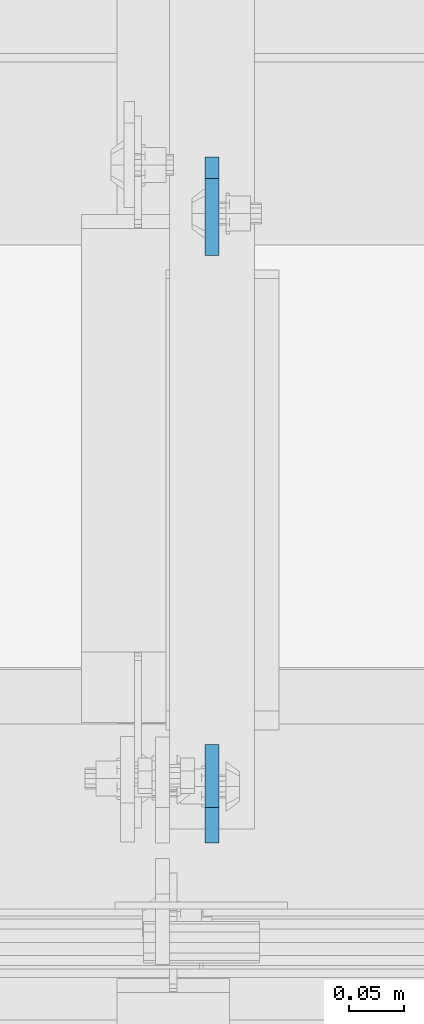
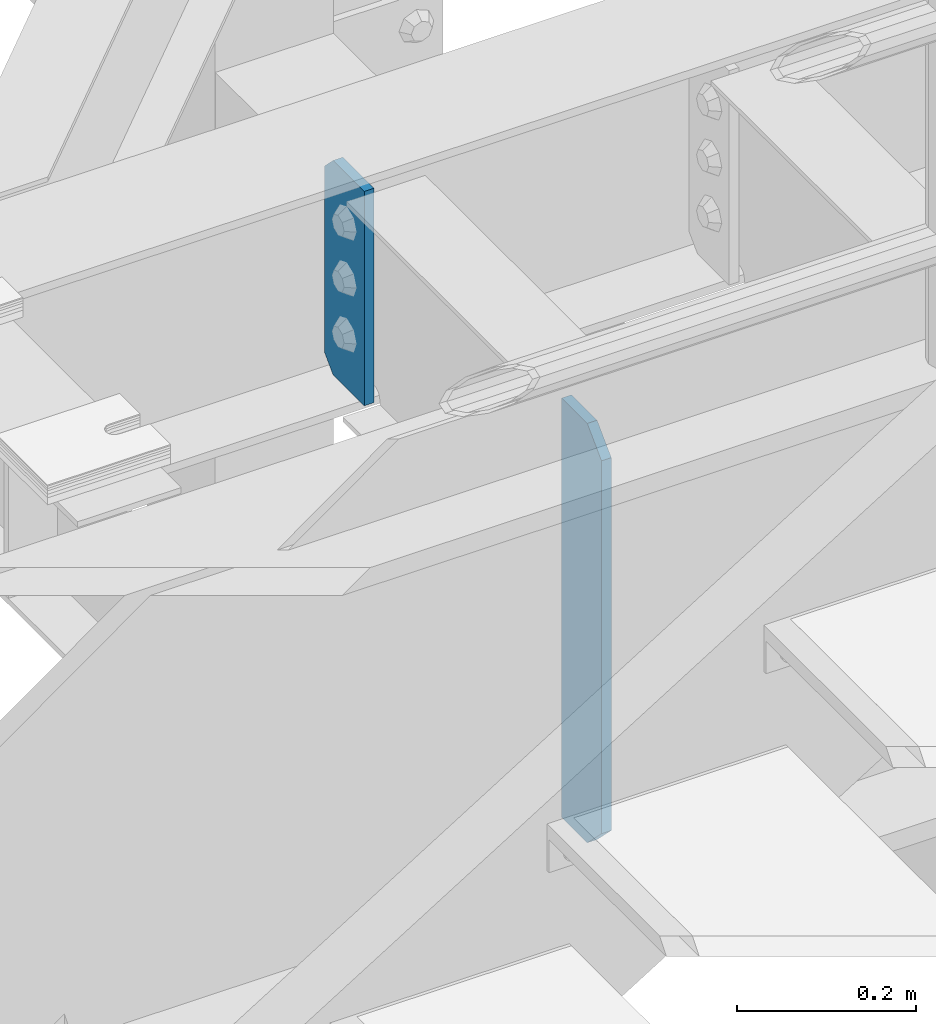
# One storey, part 1503 of 1876: 2 plates, 2 elements without a shape of their own.
"""IFC2X3 building model written with IfcOpenShell, lengths in millimetres."""

import ifcopenshell
import ifcopenshell.guid

model = None  # the IFC model being written
_history = None  # IfcOwnerHistory: only IFC2X3 demands one
_inside = {}  # id of a spatial element -> (the spatial element, [elements in it])
_under = {}  # id of a project, library or spatial element -> (it, [spatial elements below it])
_declared = {}  # id of a project -> (the project, [libraries it declares])
_typed = {}  # id of a type object -> (the type object, [elements of that type])
_made_of = {}  # id of a material, layer set ... -> (it, [elements and type objects made of it])


def new_model(schema):
    """Start an empty IFC model of exactly this schema.

    Asked for "IFC4X3", IfcOpenShell would pick the latest addendum, in which some entities
    have other attributes; the version numbers below select the first issue.
    IFC2X3 requires an IfcOwnerHistory on every rooted entity: one is made here for all.
    """
    global model, _history
    if schema == "IFC4X3":
        model = ifcopenshell.file(schema_version=(4, 3, 0, 0))
    else:
        model = ifcopenshell.file(schema=schema)
    _inside.clear()
    _under.clear()
    _declared.clear()
    _typed.clear()
    _made_of.clear()
    _history = None
    if model.schema == "IFC2X3":
        org = make("IfcOrganization", Name="unknown")
        user = make(
            "IfcPersonAndOrganization",
            ThePerson=make("IfcPerson", FamilyName="unknown"),
            TheOrganization=org,
        )
        app = make(
            "IfcApplication",
            ApplicationDeveloper=org,
            Version="unknown",
            ApplicationFullName="unknown",
            ApplicationIdentifier="unknown",
        )
        _history = make(
            "IfcOwnerHistory",
            OwningUser=user,
            OwningApplication=app,
            ChangeAction="ADDED",
            CreationDate=0,
        )
    return model


def make(cls, **values):
    """One entity of the class cls with the attributes given. An attribute that is None is left unset."""
    return model.create_entity(
        cls, **{name: value for name, value in values.items() if value is not None}
    )


def rooted(cls, **values):
    """An entity with a GlobalId (a new one), such as an element, a storey or a relation."""
    return make(cls, GlobalId=ifcopenshell.guid.new(), OwnerHistory=_history, **values)


def si_unit(unit_type, name, prefix=None):
    """IfcSIUnit, for example si_unit("LENGTHUNIT", "METRE", prefix="MILLI")."""
    return make("IfcSIUnit", UnitType=unit_type, Prefix=prefix, Name=name)


def assignment(units):
    """IfcUnitAssignment: the units of a project."""
    return None if units is None else make("IfcUnitAssignment", Units=units)


def point(xyz):
    """IfcCartesianPoint."""
    return None if xyz is None else make("IfcCartesianPoint", Coordinates=xyz)


def direction(xyz):
    """IfcDirection."""
    return None if xyz is None else make("IfcDirection", DirectionRatios=xyz)


def frame(location, z_axis=None, x_axis=None):
    """IfcAxis2Placement3D, a coordinate frame: its origin and axes. An axis left out is left unset."""
    return make(
        "IfcAxis2Placement3D",
        Location=point(location),
        Axis=direction(z_axis),
        RefDirection=direction(x_axis),
    )


def origin_with_axes():
    """The frame at (0, 0, 0) with the z axis (0, 0, 1) and the x axis (1, 0, 0) written out."""
    return frame((0.0, 0.0, 0.0), z_axis=(0.0, 0.0, 1.0), x_axis=(1.0, 0.0, 0.0))


def place(relative_to, where):
    """IfcLocalPlacement: puts the frame where relative to a parent placement (None: the world)."""
    return make(
        "IfcLocalPlacement", PlacementRelTo=relative_to, RelativePlacement=where
    )


def context(
    kind, dimensions, precision=None, world=None, true_north=None, identifier=None
):
    """IfcGeometricRepresentationContext, for example the 3D "Model" context."""
    return make(
        "IfcGeometricRepresentationContext",
        ContextIdentifier=identifier,
        ContextType=kind,
        CoordinateSpaceDimension=dimensions,
        Precision=precision,
        WorldCoordinateSystem=world,
        TrueNorth=true_north,
    )


def subcontext(parent, identifier, kind, view, scale=None):
    """IfcGeometricRepresentationSubContext, for example "Body" below "Model"."""
    return make(
        "IfcGeometricRepresentationSubContext",
        ContextIdentifier=identifier,
        ContextType=kind,
        ParentContext=parent,
        TargetScale=scale,
        TargetView=view,
    )


def project(units=None, contexts=None):
    """IfcProject with its units and contexts."""
    return rooted(
        "IfcProject",
        Name="project",
        RepresentationContexts=contexts,
        UnitsInContext=assignment(units),
    )


def spatial(cls, under=None, at=None, **own):
    """A site, building, storey or space (cls), placed at a placement, below another one or the project."""
    s = rooted(cls, ObjectPlacement=at, **own)
    if under is not None:
        _under.setdefault(under.id(), (under, []))[1].append(s)
    return s


def faces_of(points, faces, orient=None, outer=None):
    """IfcFace entities. A face is a list of loops; a loop is a list of indices into points, from 0.

    orient and outer hold one flag for each loop. By default every Orientation is true, the
    first loop of a face is its IfcFaceOuterBound and the others are IfcFaceBound.
    """
    made = []
    for i, loops in enumerate(faces):
        bounds = []
        for j, loop in enumerate(loops):
            is_outer = j == 0 if outer is None else outer[i][j]
            bounds.append(
                make(
                    "IfcFaceOuterBound" if is_outer else "IfcFaceBound",
                    Bound=make("IfcPolyLoop", Polygon=[points[k] for k in loop]),
                    Orientation=True if orient is None else orient[i][j],
                )
            )
        made.append(make("IfcFace", Bounds=bounds))
    return made


def faceted_brep(points, faces, orient=None, outer=None, voids=None):
    """IfcFacetedBrep: a solid bounded by flat faces; with voids (closed shells), ...WithVoids."""
    shared = [point(p) for p in points]
    hull = make("IfcClosedShell", CfsFaces=faces_of(shared, faces, orient, outer))
    if voids is None:
        return make("IfcFacetedBrep", Outer=hull)
    return make(
        "IfcFacetedBrepWithVoids",
        Outer=hull,
        Voids=[
            make(cls, CfsFaces=faces_of(shared, fs, o, b)) for cls, fs, o, b in voids
        ],
    )


def shape(context_of_items, identifier, shape_type, items):
    """IfcShapeRepresentation: the items that make up one representation, for example the "Body"."""
    return make(
        "IfcShapeRepresentation",
        ContextOfItems=context_of_items,
        RepresentationIdentifier=identifier,
        RepresentationType=shape_type,
        Items=items,
    )


def material(Name=None, Category=None):
    """IfcMaterial."""
    return make("IfcMaterial", Name=Name, Category=Category)


def made_of(thing, what):
    """Note that an element or type object is made of a material, layer set ...; save() writes the relation."""
    if what is not None:
        _made_of.setdefault(what.id(), (what, []))[1].append(thing)
    return thing


def type_object(cls, material=None, **own):
    """A type object (cls), such as IfcWallType, which elements share."""
    return made_of(rooted(cls, **own), material)


def element(
    cls,
    number,
    at=None,
    inside=None,
    cuts=None,
    type_object=None,
    material=None,
    context=None,
    identifier="Body",
    shape_type=None,
    held_by="IfcProductDefinitionShape",
    body=None,
    shapes=None,
    **own,
):
    """One element of the class cls, such as IfcWall. Its Tag is "e" and its number.

    at: its placement. inside: the storey or other place that contains it. cuts: it is an
    opening in that element (IfcRelVoidsElement). A single representation is given by context,
    identifier, shape_type and body (its items); several are given by shapes. held_by: the class
    of the entity that holds the representations. save() writes the other relations.
    """
    e = rooted(cls, Tag="e%d" % number, ObjectPlacement=at, **own)
    if body is not None:
        shapes = [shape(context, identifier, shape_type, body)]
    if shapes is not None:
        e.Representation = make(held_by, Representations=shapes)
    if inside is not None:
        _inside.setdefault(inside.id(), (inside, []))[1].append(e)
    if cuts is not None:
        rooted(
            "IfcRelVoidsElement", RelatingBuildingElement=cuts, RelatedOpeningElement=e
        )
    if type_object is not None:
        _typed.setdefault(type_object.id(), (type_object, []))[1].append(e)
    return made_of(e, material)


def aggregate(whole, parts):
    """IfcRelAggregates: a whole, such as a stair, and the parts it consists of."""
    return rooted("IfcRelAggregates", RelatingObject=whole, RelatedObjects=parts)


def save(model, path):
    """Write the relations noted so far, then the file.

    IfcRelAggregates (storeys below a building ...), IfcRelContainedInSpatialStructure (elements
    in a storey), IfcRelDefinesByType, IfcRelAssociatesMaterial and IfcRelDeclares: one each for
    every whole, place, type object, material and project.
    """
    for whole, parts in _under.values():
        aggregate(whole, parts)
    for where, things in _inside.values():
        rooted(
            "IfcRelContainedInSpatialStructure",
            RelatedElements=things,
            RelatingStructure=where,
        )
    for kind, things in _typed.values():
        rooted("IfcRelDefinesByType", RelatedObjects=things, RelatingType=kind)
    for what, things in _made_of.values():
        rooted("IfcRelAssociatesMaterial", RelatedObjects=things, RelatingMaterial=what)
    for by, libraries in _declared.values():
        rooted("IfcRelDeclares", RelatingContext=by, RelatedDefinitions=libraries)
    model.write(path)


model = new_model("IFC2X3")

# Units and contexts
model_context = context("Model", 3, precision=1e-05, world=origin_with_axes())
body_context = subcontext(model_context, "Body", "Model", "MODEL_VIEW")
ifc_project = project(units=[si_unit("LENGTHUNIT", "METRE", prefix="MILLI"), si_unit("AREAUNIT", "SQUARE_METRE"), si_unit("VOLUMEUNIT", "CUBIC_METRE"), si_unit("MASSUNIT", "GRAM", prefix="KILO"), si_unit("TIMEUNIT", "SECOND"), si_unit("PLANEANGLEUNIT", "RADIAN"), si_unit("SOLIDANGLEUNIT", "STERADIAN"), si_unit("THERMODYNAMICTEMPERATUREUNIT", "DEGREE_CELSIUS"), si_unit("LUMINOUSINTENSITYUNIT", "LUMEN")], contexts=[model_context])

# Site, building, storey
site_placement = place(None, origin_with_axes())
site = spatial("IfcSite", under=ifc_project, at=site_placement, CompositionType="ELEMENT")
building_placement = place(site_placement, origin_with_axes())
building = spatial("IfcBuilding", under=site, at=building_placement, Name="Undefined", CompositionType="ELEMENT")
storey_placement = place(building_placement, origin_with_axes())
storey = spatial("IfcBuildingStorey", under=building, at=storey_placement, Name="Undefined", CompositionType="ELEMENT", Elevation=0.0)

# Assembly, plate
assembly_1_placement = place(storey_placement, origin_with_axes())
assembly_1 = element("IfcElementAssembly", 1, at=assembly_1_placement, inside=storey, Name="BEAM", AssemblyPlace="NOTDEFINED", PredefinedType="RIGID_FRAME")
ifc_material = material(Name="STEEL/A36")
plate_type = type_object("IfcPlateType", PredefinedType="NOTDEFINED")
plate_1_placement = place(assembly_1_placement, frame((5749.92499990463, -4564.85625, 17386.3), z_axis=(0.0, 0.0, 1.0), x_axis=(0.0, 1.0, 0.0)))
plate_1 = element("IfcPlate", 2, at=plate_1_placement, type_object=plate_type, material=ifc_material, Name="PLATE", context=body_context, shape_type="Brep", body=[
    faceted_brep([(0.0, -6.34999999999991, 31.75), (0.0, -6.34999999999991, 539.75), (0.0, 6.34999999999991, 539.75), (0.0, 6.34999999999991, 31.75), (31.75, -6.34999999999991, 571.5), (31.75, 6.34999999999991, 571.5), (88.9000015258789, -6.34999999999991, 571.5), (88.9000015258789, 6.34999999999991, 571.5), (88.9000015258789, -6.34999999999991, 0.0), (88.9000015258789, 6.34999999999991, 0.0), (31.75, -6.34999999999991, 0.0), (31.75, 6.34999999999991, 0.0)], [[[0, 1, 2, 3]], [[1, 4, 5, 2]], [[4, 6, 7, 5]], [[6, 8, 9, 7]], [[8, 10, 11, 9]], [[10, 0, 3, 11]], [[5, 7, 9, 11, 3, 2]], [[10, 8, 6, 4, 1, 0]]]),
])
aggregate(assembly_1, [plate_1])

assembly_2_placement = place(storey_placement, origin_with_axes())
assembly_2 = element("IfcElementAssembly", 3, at=assembly_2_placement, inside=storey, Name="BEAM", AssemblyPlace="NOTDEFINED", PredefinedType="RIGID_FRAME")
plate_2_placement = place(assembly_2_placement, frame((5749.92499988935, -3946.525, 17679.9875), z_axis=(0.0, 0.0, 1.0), x_axis=(0.0, -1.0, 0.0)))
plate_2 = element("IfcPlate", 4, at=plate_2_placement, type_object=plate_type, material=ifc_material, Name="PLATE", context=body_context, shape_type="Brep", body=[
    faceted_brep([(0.0, -6.35000000000196, 19.0499992370605), (9.09494701772928e-13, -6.34999999999832, 273.050006866455), (-2.72848410531878e-12, 6.34999999999923, 273.050006866455), (0.0, 6.35000000000105, 19.0499992370605), (19.0499992370578, -6.35000000000696, 292.100006103516), (19.049999237056, 6.3499999999915, 292.100006103516), (88.9000015258789, -6.35000000000036, 292.100006103516), (88.9000015258789, 6.35000000000036, 292.100006103516), (88.9000015258789, -6.34999999999991, 0.0), (88.9000015258789, 6.34999999999991, 0.0), (19.0499992370642, -6.35000000000105, 0.0), (19.0499992370633, 6.35000000000105, 0.0)], [[[0, 1, 2, 3]], [[1, 4, 5, 2]], [[4, 6, 7, 5]], [[6, 8, 9, 7]], [[8, 10, 11, 9]], [[10, 0, 3, 11]], [[5, 7, 9, 11, 3, 2]], [[10, 8, 6, 4, 1, 0]]]),
])
aggregate(assembly_2, [plate_2])

save(model, "model.ifc")
